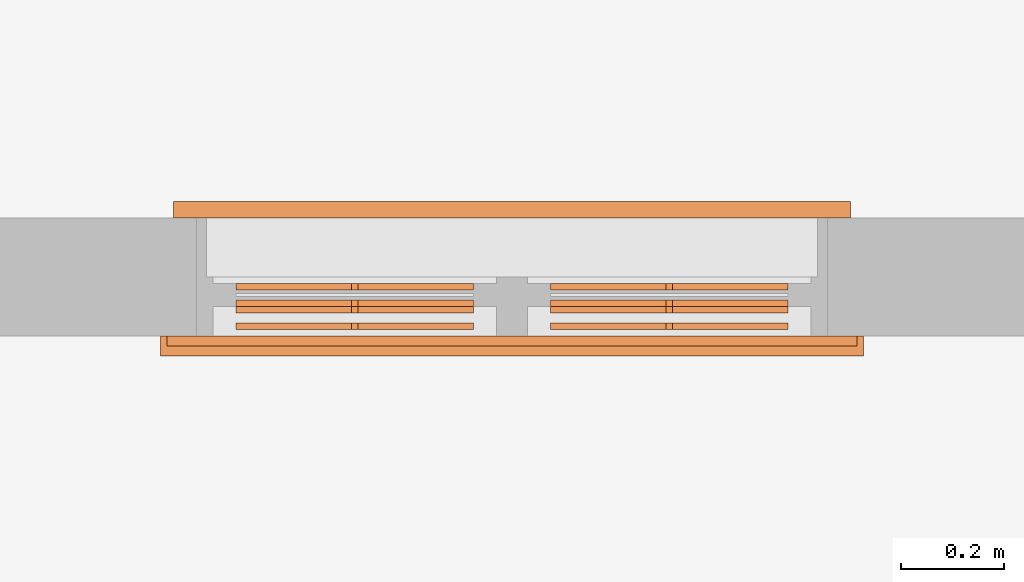
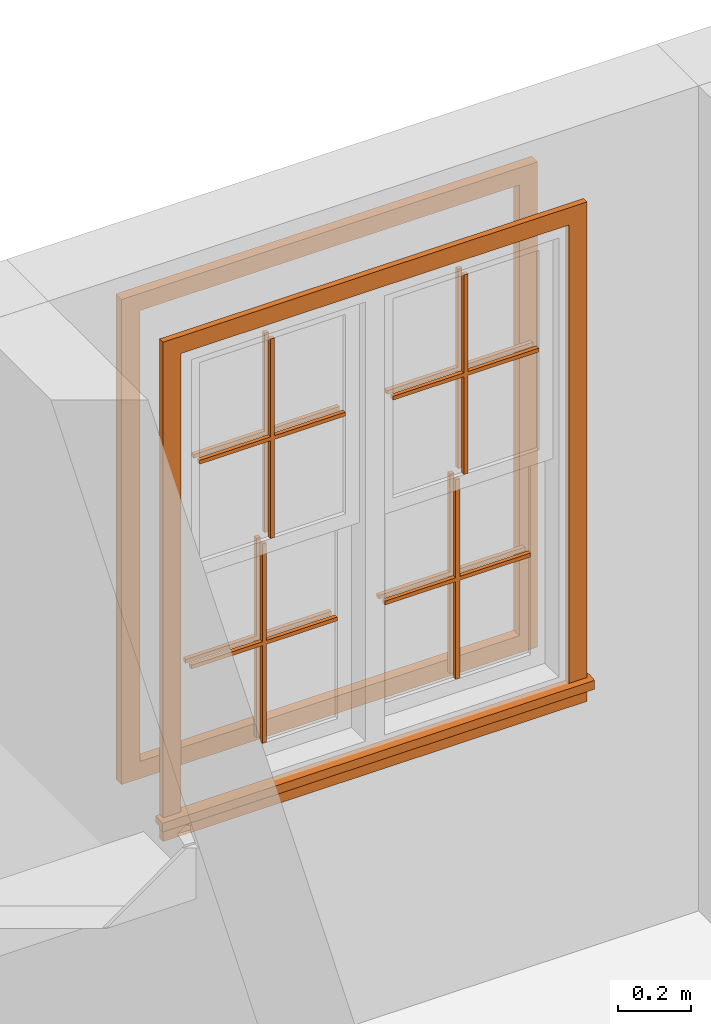
# One storey, part 6 of 6: 6 proxies.
"""IFC2X3 building model written with IfcOpenShell, lengths in feet."""

from ifc_helpers import new_model, entity, si_unit, converted_unit, derived_unit, direction, frame, origin, origin_2d_with_axis, place, context, subcontext, project, spatial, polyline, rectangle, outline, extrude, source, transform, mapped, material, material_list, type_object, type_shapes, element, save


model = new_model("IFC2X3")

# Units and contexts
model_context = context("Model", 3, precision=0.0001, world=origin(), true_north=direction((6.123031769111886e-17, 1.0)))
body_context = subcontext(model_context, "Body", "Model", "MODEL_VIEW")
ifc_project = project(units=[converted_unit("LENGTHUNIT", "FOOT", entity("IfcLengthMeasure", 0.3048), si_unit("LENGTHUNIT", "METRE"), dimensions=[1, 0, 0, 0, 0, 0, 0]), converted_unit("AREAUNIT", "SQUARE FOOT", entity("IfcAreaMeasure", 0.09290304), si_unit("AREAUNIT", "SQUARE_METRE"), dimensions=[2, 0, 0, 0, 0, 0, 0]), converted_unit("VOLUMEUNIT", "CUBIC FOOT", entity("IfcVolumeMeasure", 0.028316846592000004), si_unit("VOLUMEUNIT", "CUBIC_METRE"), dimensions=[3, 0, 0, 0, 0, 0, 0]), converted_unit("PLANEANGLEUNIT", "DEGREE", entity("IfcPlaneAngleMeasure", 0.017453292519943278), si_unit("PLANEANGLEUNIT", "RADIAN"), dimensions=[0, 0, 0, 0, 0, 0, 0]), si_unit("MASSUNIT", "GRAM", prefix="KILO"), derived_unit("MASSDENSITYUNIT", [(si_unit("MASSUNIT", "GRAM", prefix="KILO"), 1), (si_unit("LENGTHUNIT", "METRE"), -3)]), derived_unit("IONCONCENTRATIONUNIT", [(si_unit("MASSUNIT", "GRAM", prefix="KILO"), 1), (si_unit("LENGTHUNIT", "METRE"), -3)]), derived_unit("MOMENTOFINERTIAUNIT", [(si_unit("LENGTHUNIT", "METRE"), 4)]), si_unit("TIMEUNIT", "SECOND"), si_unit("FREQUENCYUNIT", "HERTZ"), si_unit("THERMODYNAMICTEMPERATUREUNIT", "DEGREE_CELSIUS"), derived_unit("THERMALTRANSMITTANCEUNIT", [(si_unit("MASSUNIT", "GRAM", prefix="KILO"), 1), (si_unit("THERMODYNAMICTEMPERATUREUNIT", "KELVIN"), -1), (si_unit("TIMEUNIT", "SECOND"), -3)]), derived_unit("THERMALCONDUCTANCEUNIT", [(si_unit("MASSUNIT", "GRAM", prefix="KILO"), 1), (si_unit("THERMODYNAMICTEMPERATUREUNIT", "KELVIN"), -1), (si_unit("TIMEUNIT", "SECOND"), -3), (si_unit("LENGTHUNIT", "METRE"), 1)]), derived_unit("VOLUMETRICFLOWRATEUNIT", [(si_unit("LENGTHUNIT", "METRE"), 3), (si_unit("TIMEUNIT", "SECOND"), -1)]), derived_unit("MASSFLOWRATEUNIT", [(si_unit("MASSUNIT", "GRAM", prefix="KILO"), 1), (si_unit("TIMEUNIT", "SECOND"), -1)]), derived_unit("ROTATIONALFREQUENCYUNIT", [(si_unit("TIMEUNIT", "SECOND"), -1)]), si_unit("ELECTRICCURRENTUNIT", "AMPERE"), si_unit("ELECTRICVOLTAGEUNIT", "VOLT"), si_unit("POWERUNIT", "WATT"), converted_unit("FORCEUNIT", "KIP", entity("IfcForceMeasure", 2.088543423315013e-05), si_unit("FORCEUNIT", "NEWTON"), dimensions=[1, 1, -2, 0, 0, 0, 0]), si_unit("ILLUMINANCEUNIT", "LUX"), si_unit("LUMINOUSFLUXUNIT", "LUMEN"), si_unit("LUMINOUSINTENSITYUNIT", "CANDELA"), si_unit("ENERGYUNIT", "JOULE"), derived_unit("USERDEFINED", [(si_unit("MASSUNIT", "GRAM", prefix="KILO"), -1), (si_unit("LENGTHUNIT", "METRE"), -2), (si_unit("TIMEUNIT", "SECOND"), 3), (si_unit("LUMINOUSFLUXUNIT", "LUMEN"), 1)]), derived_unit("USERDEFINED", [(si_unit("MASSUNIT", "GRAM", prefix="KILO"), 1), (si_unit("TIMEUNIT", "SECOND"), -3), (si_unit("LENGTHUNIT", "METRE"), 3), (si_unit("ELECTRICCURRENTUNIT", "AMPERE"), -2)]), derived_unit("SOUNDPOWERUNIT", [(si_unit("MASSUNIT", "GRAM", prefix="KILO"), 1), (si_unit("TIMEUNIT", "SECOND"), -3), (si_unit("LENGTHUNIT", "METRE"), 2)]), derived_unit("SOUNDPRESSUREUNIT", [(si_unit("MASSUNIT", "GRAM", prefix="KILO"), 1), (si_unit("LENGTHUNIT", "METRE"), -1), (si_unit("TIMEUNIT", "SECOND"), -2)]), derived_unit("LINEARVELOCITYUNIT", [(si_unit("LENGTHUNIT", "METRE"), 1), (si_unit("TIMEUNIT", "SECOND"), -1)]), si_unit("PRESSUREUNIT", "PASCAL"), derived_unit("USERDEFINED", [(si_unit("MASSUNIT", "GRAM", prefix="KILO"), 1), (si_unit("LENGTHUNIT", "METRE"), -2), (si_unit("TIMEUNIT", "SECOND"), -2)]), derived_unit("LINEARFORCEUNIT", [(si_unit("MASSUNIT", "GRAM", prefix="KILO"), 1), (si_unit("TIMEUNIT", "SECOND"), -2)]), derived_unit("PLANARFORCEUNIT", [(si_unit("MASSUNIT", "GRAM", prefix="KILO"), 1), (si_unit("LENGTHUNIT", "METRE"), -1), (si_unit("TIMEUNIT", "SECOND"), -2)]), derived_unit("SPECIFICHEATCAPACITYUNIT", [(si_unit("THERMODYNAMICTEMPERATUREUNIT", "KELVIN"), -1), (si_unit("LENGTHUNIT", "METRE"), 2), (si_unit("TIMEUNIT", "SECOND"), -2)]), derived_unit("HEATFLUXDENSITYUNIT", [(si_unit("MASSUNIT", "GRAM", prefix="KILO"), 1), (si_unit("TIMEUNIT", "SECOND"), -3)]), derived_unit("HEATINGVALUEUNIT", [(si_unit("LENGTHUNIT", "METRE"), 2), (si_unit("TIMEUNIT", "SECOND"), -2)]), derived_unit("VAPORPERMEABILITYUNIT", [(si_unit("LENGTHUNIT", "METRE"), -1), (si_unit("TIMEUNIT", "SECOND"), 1)]), derived_unit("DYNAMICVISCOSITYUNIT", [(si_unit("MASSUNIT", "GRAM", prefix="KILO"), 1), (si_unit("TIMEUNIT", "SECOND"), -1), (si_unit("LENGTHUNIT", "METRE"), -1)]), derived_unit("THERMALEXPANSIONCOEFFICIENTUNIT", [(si_unit("THERMODYNAMICTEMPERATUREUNIT", "KELVIN"), -1)]), derived_unit("MODULUSOFELASTICITYUNIT", [(si_unit("MASSUNIT", "GRAM", prefix="KILO"), 1), (si_unit("LENGTHUNIT", "METRE"), -1), (si_unit("TIMEUNIT", "SECOND"), -2)]), derived_unit("ISOTHERMALMOISTURECAPACITYUNIT", [(si_unit("LENGTHUNIT", "METRE"), 3), (si_unit("MASSUNIT", "GRAM", prefix="KILO"), -1)]), derived_unit("MOISTUREDIFFUSIVITYUNIT", [(si_unit("TIMEUNIT", "SECOND"), -1), (si_unit("LENGTHUNIT", "METRE"), 2)]), derived_unit("MASSPERLENGTHUNIT", [(si_unit("MASSUNIT", "GRAM", prefix="KILO"), 1), (si_unit("LENGTHUNIT", "METRE"), -1)]), derived_unit("THERMALRESISTANCEUNIT", [(si_unit("MASSUNIT", "GRAM", prefix="KILO"), -1), (si_unit("TIMEUNIT", "SECOND"), 3), (si_unit("THERMODYNAMICTEMPERATUREUNIT", "KELVIN"), 1)]), derived_unit("ACCELERATIONUNIT", [(si_unit("LENGTHUNIT", "METRE"), 1), (si_unit("TIMEUNIT", "SECOND"), -2)]), derived_unit("ANGULARVELOCITYUNIT", [(si_unit("TIMEUNIT", "SECOND"), -1), (si_unit("PLANEANGLEUNIT", "RADIAN"), 1)]), derived_unit("LINEARSTIFFNESSUNIT", [(si_unit("MASSUNIT", "GRAM", prefix="KILO"), 1), (si_unit("TIMEUNIT", "SECOND"), -2)]), derived_unit("WARPINGCONSTANTUNIT", [(si_unit("LENGTHUNIT", "METRE"), 6)]), derived_unit("LINEARMOMENTUNIT", [(si_unit("MASSUNIT", "GRAM", prefix="KILO"), 1), (si_unit("LENGTHUNIT", "METRE"), 1), (si_unit("TIMEUNIT", "SECOND"), -2)]), derived_unit("TORQUEUNIT", [(si_unit("MASSUNIT", "GRAM", prefix="KILO"), 1), (si_unit("LENGTHUNIT", "METRE"), 2), (si_unit("TIMEUNIT", "SECOND"), -2)])], contexts=[model_context])

# Site, building, storey
site_placement = place(None, origin())
site = spatial("IfcSite", under=ifc_project, at=site_placement, CompositionType="ELEMENT")
building_placement = place(site_placement, origin())
building = spatial("IfcBuilding", under=site, at=building_placement, CompositionType="ELEMENT")
storey_placement = place(building_placement, origin())
storey = spatial("IfcBuildingStorey", under=building, at=storey_placement, Name="Level 1", CompositionType="ELEMENT", Elevation=0.0)

# Proxies
ifc_material_1 = material(Name="Clad - White")
ifc_material_2 = material(Name="Wood - Stained")
ifc_material_list = material_list([ifc_material_1, ifc_material_2])
building_element_proxy_type_1 = type_object("IfcBuildingElementProxyType", Name="Muntin Pattern_2x2:Muntin Pattern_2x2", PredefinedType="NOTDEFINED", material=ifc_material_list)
shared_shape_1 = source(origin(), body_context, "Body", "SweptSolid", [
    extrude(outline(polyline([(0.020833333333444504, -0.020833333333421394), (1.0885416666661296, -0.020833333333421394), (1.0885416666661296, 0.020833333333239508), (0.0208333333334636, 0.020833333333239498), (0.020833333333463596, 0.7526041666666206), (-0.02083333333319382, 0.7526041666666206), (-0.020833333333193815, 0.020833333333267774), (-1.088541666666626, 0.02083333333326775), (-1.088541666666626, -0.020833333333383972), (-0.020833333333217574, -0.02083333333338397), (-0.02083333333321757, -0.7526041666663225), (0.020833333333444507, -0.7526041666663225), (0.020833333333444504, -0.020833333333421394)])), frame((0.0, 0.031249999999993856, 1.088541666666278), z_axis=(0.0, 1.0, 0.0), x_axis=(0.0, 0.0, 1.0)), (0.0, 0.0, 1.0), 0.041666666666653626),
    extrude(outline(polyline([(0.020833333333366566, -0.020833333333411974), (1.0885416666664214, -0.020833333333411974), (1.0885416666664214, 0.02083333333324877), (0.02083333333337345, 0.02083333333324877), (0.02083333333337345, 0.7526041666666126), (-0.020833333333290627, 0.7526041666666126), (-0.020833333333290627, 0.020833333333276638), (-1.0885416666665682, 0.020833333333276638), (-1.0885416666665682, -0.020833333333395432), (-0.02083333333330173, -0.020833333333395432), (-0.02083333333330173, -0.7526041666663306), (0.020833333333366566, -0.7526041666663306), (0.020833333333366566, -0.020833333333411974)])), frame((0.0, -0.07291666666670289, 1.0885416666665608), z_axis=(0.0, 1.0, 0.0), x_axis=(0.0, 0.0, 1.0)), (0.0, 0.0, 1.0), 0.04166666666665375),
])
type_shapes(building_element_proxy_type_1, [shared_shape_1])
for number, where, z_axis, x_axis, name in (
    (1, (3.5510244147490595, 16.115163631404968, 5.5729166666665435), (0.0, 0.0, 1.0), (-1.0, 0.0, 0.0), "Muntin Pattern_2x2:Muntin Pattern_2x2"),
    (2, (3.551024414749059, 16.260996964738307, 3.2499999999999925), (0.0, 0.0, 1.0), (-1.0, 0.0, 0.0), "Muntin Pattern_2x2:Muntin Pattern_2x2"),
):
    element("IfcBuildingElementProxy", number, at=place(storey_placement, frame(where, z_axis=z_axis, x_axis=x_axis)), inside=storey, type_object=building_element_proxy_type_1, material=ifc_material_list, Name=name, ObjectType="Muntin Pattern_2x2:Muntin Pattern_2x2", context=body_context, shape_type="MappedRepresentation", body=[
        mapped(shared_shape_1, transform((0.0, 0.0, 0.0), scale=1.0)),
    ])
building_element_proxy_type_2 = type_object("IfcBuildingElementProxyType", Name="Muntin Pattern_2x2:Muntin Pattern_2x2", PredefinedType="NOTDEFINED", material=ifc_material_list)
shared_shape_2 = source(origin(), body_context, "Body", "SweptSolid", [
    extrude(outline(polyline([(0.02083333333344428, -0.020833333333421356), (1.088541666666035, -0.020833333333421356), (1.088541666666035, 0.020833333333239546), (0.020833333333463377, 0.020833333333239536), (0.020833333333463374, 0.7526041666669812), (-0.02083333333319404, 0.7526041666669812), (-0.020833333333194037, 0.02083333333326781), (-1.0885416666665317, 0.020833333333267787), (-1.0885416666665317, -0.020833333333383934), (-0.020833333333217796, -0.02083333333338393), (-0.020833333333217793, -0.7526041666666832), (0.020833333333444285, -0.7526041666666832), (0.02083333333344428, -0.020833333333421356)])), frame((0.0, -0.07291666666664748, 1.088541666666183), z_axis=(0.0, 1.0, 0.0), x_axis=(0.0, 0.0, 1.0)), (0.0, 0.0, 1.0), 0.041666666666653626),
    extrude(outline(polyline([(0.020833333333366788, -0.020833333333411936), (1.0885416666663268, -0.020833333333411936), (1.0885416666663268, 0.02083333333324881), (0.02083333333337367, 0.02083333333324881), (0.02083333333337367, 0.7526041666669732), (-0.020833333333290405, 0.7526041666669732), (-0.020833333333290405, 0.020833333333276676), (-1.0885416666664733, 0.020833333333276676), (-1.0885416666664733, -0.020833333333395394), (-0.020833333333301507, -0.020833333333395394), (-0.020833333333301507, -0.7526041666666914), (0.020833333333366788, -0.7526041666666914), (0.020833333333366788, -0.020833333333411936)])), frame((0.0, 0.031250000000049155, 1.0885416666664667), z_axis=(0.0, 1.0, 0.0), x_axis=(0.0, 0.0, 1.0)), (0.0, 0.0, 1.0), 0.04166666666665375),
])
type_shapes(building_element_proxy_type_2, [shared_shape_2])
for number, where, name in (
    (3, (5.545816081415656, 16.115163631404975, 5.57291666666673), "Muntin Pattern_2x2:Muntin Pattern_2x2"),
    (4, (5.54581608141565, 16.26099696473831, 3.2499999999999734), "Muntin Pattern_2x2:Muntin Pattern_2x2"),
):
    element("IfcBuildingElementProxy", number, at=place(storey_placement, frame(where)), inside=storey, type_object=building_element_proxy_type_2, material=ifc_material_list, Name=name, ObjectType="Muntin Pattern_2x2:Muntin Pattern_2x2", context=body_context, shape_type="MappedRepresentation", body=[
        mapped(shared_shape_2, transform((0.0, 0.0, 0.0), scale=1.0)),
    ])
building_element_proxy_type_3 = type_object("IfcBuildingElementProxyType", Name="Trim-Window-Exterior-Flat:with Sill", PredefinedType="NOTDEFINED", material=ifc_material_1)
shared_shape_3 = source(origin(), body_context, "Body", "SweptSolid", [
    extrude(rectangle(XDim=4.374999999999989, YDim=0.1875000000000071, at=origin_2d_with_axis()), frame((0.0, -5.166526807364594, 0.0), z_axis=(0.0, 0.0, 1.0), x_axis=(-1.0, 0.0, 0.0)), (0.0, 0.0, 1.0), 0.062499999999999986),
    extrude(outline(polyline([(-0.0624999999999706, -0.0524593146393153), (0.0, -0.0524593146393153), (0.0, -0.021069455337204168), (0.062499999999909524, -0.021069455337204168), (0.062499999999909524, 0.05170735202735699), (0.0, 0.05170735202735699), (-0.062499999999970586, 0.0436428358983294), (-0.0624999999999706, -0.0524593146393153)])), frame((-2.2291666666666408, -5.051707352027377, 0.0624999999999263), z_axis=(1.0, 0.0, 0.0), x_axis=(0.0, 0.0, -1.0)), (0.0, 0.0, 1.0), 4.458333333333346),
    extrude(outline(polyline([(-2.6406250000000018, -2.187499999999999), (2.5468749999999982, -2.187499999999999), (2.5468749999999982, -2.0), (-2.4531249999999947, -2.0), (-2.4531249999999947, 2.0), (2.5468749999999982, 2.0), (2.5468749999999973, 2.1874999999999902), (-2.6406250000000027, 2.1874999999999902), (-2.6406250000000018, -2.187499999999999)])), frame((0.0, -2.453125000000022, 0.0), z_axis=(0.0, 0.0, 1.0), x_axis=(0.0, -1.0, 0.0)), (0.0, 0.0, 1.0), 0.062499999999999986),
])
type_shapes(building_element_proxy_type_3, [shared_shape_3])
proxy_1_placement = place(storey_placement, frame((4.548420248082162, 16.00058029807166, 8.0), z_axis=(0.0, -1.0, 0.0), x_axis=(1.0, 0.0, 0.0)))
element("IfcBuildingElementProxy", 5, at=proxy_1_placement, inside=storey, type_object=building_element_proxy_type_3, material=ifc_material_1, Name="Trim-Window-Exterior-Flat:with Sill", ObjectType="Trim-Window-Exterior-Flat:with Sill", context=body_context, shape_type="MappedRepresentation", body=[
    mapped(shared_shape_3, transform((0.0, 0.0, 0.0), scale=1.0)),
])
building_element_proxy_type_4 = type_object("IfcBuildingElementProxyType", Name="Trim-Window-Interior-Flat:Picture Frame", PredefinedType="NOTDEFINED", material=ifc_material_2)
shared_shape_4 = source(origin(), body_context, "Body", "SweptSolid", [
    extrude(outline(polyline([(-2.145833333333326, -2.645833333333316), (2.145833333333326, -2.645833333333316), (2.145833333333326, 2.645833333333316), (-2.145833333333326, 2.645833333333316), (-2.145833333333326, -2.645833333333316)]), holes=[polyline([(-1.9583333333333401, -2.458333333333308), (-1.9583333333333406, 2.4583333333333055), (1.9583333333333255, 2.4583333333333055), (1.958333333333326, -2.458333333333308), (-1.9583333333333401, -2.458333333333308)])]), frame((0.0, -2.500000000000057, 0.0), z_axis=(0.0, 0.0, 1.0), x_axis=(-1.0, 0.0, 0.0)), (0.0, 0.0, 1.0), 0.10416666666666664),
])
type_shapes(building_element_proxy_type_4, [shared_shape_4])
proxy_2_placement = place(storey_placement, frame((4.548420248082196, 16.75058029807166, 8.0), z_axis=(0.0, 1.0, 0.0), x_axis=(-1.0, 0.0, 0.0)))
element("IfcBuildingElementProxy", 6, at=proxy_2_placement, inside=storey, type_object=building_element_proxy_type_4, material=ifc_material_2, Name="Trim-Window-Interior-Flat:Picture Frame", ObjectType="Trim-Window-Interior-Flat:Picture Frame", context=body_context, shape_type="MappedRepresentation", body=[
    mapped(shared_shape_4, transform((0.0, 0.0, 0.0), scale=1.0)),
])

save(model, "model.ifc")
